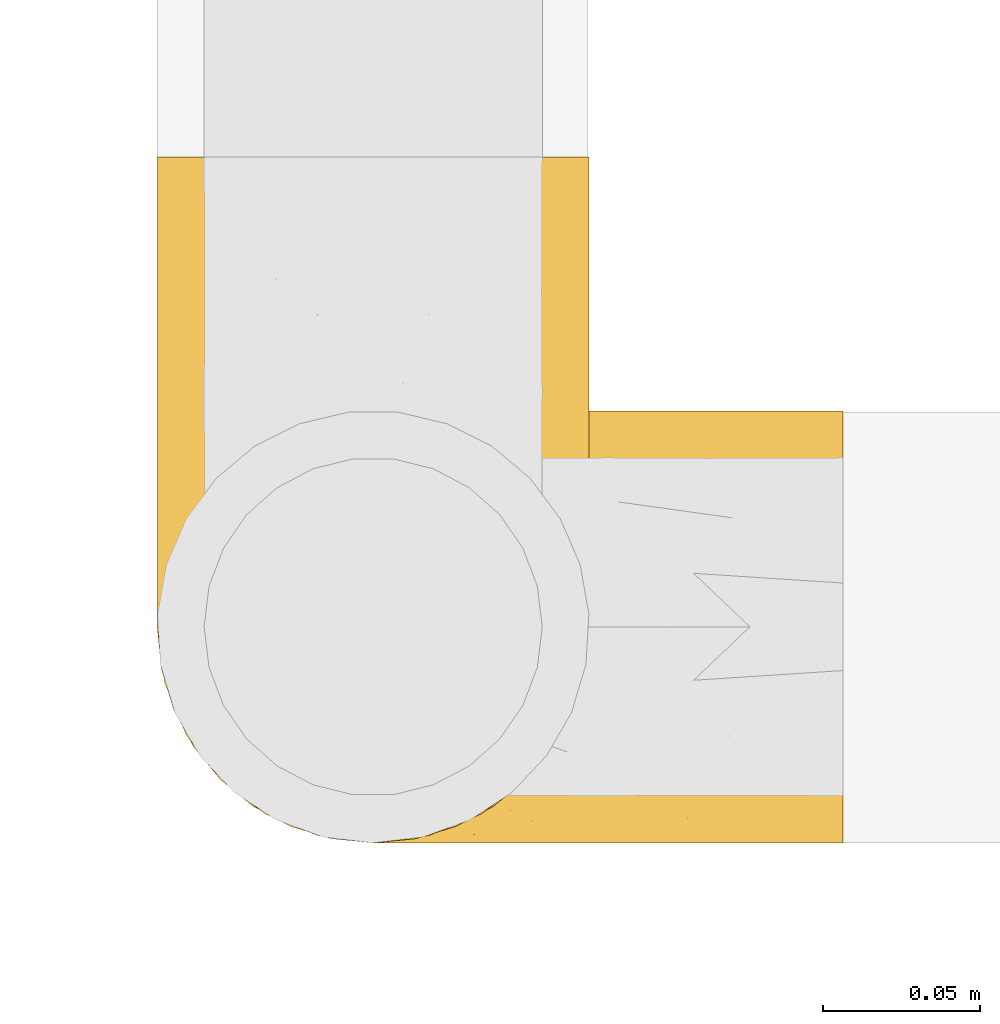
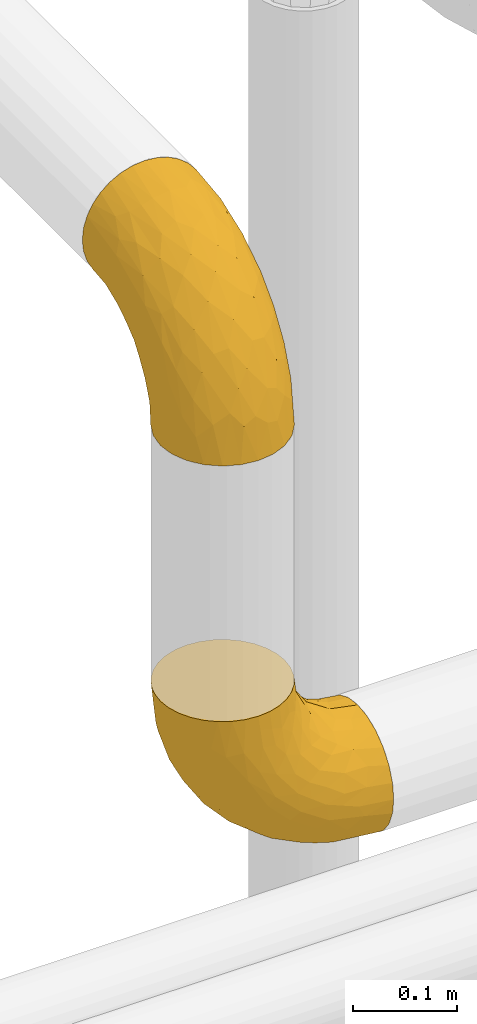
# One storey, part 436 of 827: 2 coverings.
"""IFC2X3 building model written with IfcOpenShell, lengths in millimetres."""

from ifc_helpers import new_model, entity, si_unit, converted_unit, derived_unit, direction, frame, origin, place, context, subcontext, project, spatial, faceted_brep, element, save


model = new_model("IFC2X3")

# Units and contexts
model_context = context("Model", 3, precision=0.01, world=origin(), true_north=direction((6.12303176911189e-17, 1.0)))
body_context = subcontext(model_context, "Body", "Model", "MODEL_VIEW")
ifc_project = project(units=[si_unit("LENGTHUNIT", "METRE", prefix="MILLI"), si_unit("AREAUNIT", "SQUARE_METRE"), si_unit("VOLUMEUNIT", "CUBIC_METRE"), converted_unit("PLANEANGLEUNIT", "DEGREE", entity("IfcRatioMeasure", 0.0174532925199433), si_unit("PLANEANGLEUNIT", "RADIAN"), dimensions=[0, 0, 0, 0, 0, 0, 0]), si_unit("MASSUNIT", "GRAM", prefix="KILO"), derived_unit("MASSDENSITYUNIT", [(si_unit("MASSUNIT", "GRAM", prefix="KILO"), 1), (si_unit("LENGTHUNIT", "METRE"), -3)]), derived_unit("MOMENTOFINERTIAUNIT", [(si_unit("LENGTHUNIT", "METRE"), 4)]), si_unit("TIMEUNIT", "SECOND"), si_unit("FREQUENCYUNIT", "HERTZ"), si_unit("THERMODYNAMICTEMPERATUREUNIT", "DEGREE_CELSIUS"), derived_unit("THERMALTRANSMITTANCEUNIT", [(si_unit("MASSUNIT", "GRAM", prefix="KILO"), 1), (si_unit("THERMODYNAMICTEMPERATUREUNIT", "KELVIN"), -1), (si_unit("TIMEUNIT", "SECOND"), -3)]), derived_unit("VOLUMETRICFLOWRATEUNIT", [(si_unit("LENGTHUNIT", "METRE"), 3), (si_unit("TIMEUNIT", "SECOND"), -1)]), derived_unit("MASSFLOWRATEUNIT", [(si_unit("MASSUNIT", "GRAM", prefix="KILO"), 1), (si_unit("TIMEUNIT", "SECOND"), -1)]), derived_unit("ROTATIONALFREQUENCYUNIT", [(si_unit("TIMEUNIT", "SECOND"), -1)]), si_unit("ELECTRICCURRENTUNIT", "AMPERE"), si_unit("ELECTRICVOLTAGEUNIT", "VOLT"), si_unit("POWERUNIT", "WATT"), si_unit("FORCEUNIT", "NEWTON", prefix="KILO"), si_unit("ILLUMINANCEUNIT", "LUX"), si_unit("LUMINOUSFLUXUNIT", "LUMEN"), si_unit("LUMINOUSINTENSITYUNIT", "CANDELA"), derived_unit("USERDEFINED", [(si_unit("MASSUNIT", "GRAM", prefix="KILO"), -1), (si_unit("LENGTHUNIT", "METRE"), -2), (si_unit("TIMEUNIT", "SECOND"), 3), (si_unit("LUMINOUSFLUXUNIT", "LUMEN"), 1)]), derived_unit("LINEARVELOCITYUNIT", [(si_unit("LENGTHUNIT", "METRE"), 1), (si_unit("TIMEUNIT", "SECOND"), -1)]), si_unit("PRESSUREUNIT", "PASCAL"), derived_unit("USERDEFINED", [(si_unit("LENGTHUNIT", "METRE"), -2), (si_unit("MASSUNIT", "GRAM", prefix="KILO"), 1), (si_unit("TIMEUNIT", "SECOND"), -2)]), derived_unit("LINEARFORCEUNIT", [(si_unit("MASSUNIT", "GRAM", prefix="KILO"), 1), (si_unit("LENGTHUNIT", "METRE"), 1), (si_unit("TIMEUNIT", "SECOND"), -2), (si_unit("LENGTHUNIT", "METRE"), -1)]), derived_unit("PLANARFORCEUNIT", [(si_unit("MASSUNIT", "GRAM", prefix="KILO"), 1), (si_unit("LENGTHUNIT", "METRE"), 1), (si_unit("TIMEUNIT", "SECOND"), -2), (si_unit("LENGTHUNIT", "METRE"), -2)])], contexts=[model_context])

# Site, building, storey
site_placement = place(None, origin())
site = spatial("IfcSite", under=ifc_project, at=site_placement, CompositionType="ELEMENT")
building_placement = place(site_placement, origin())
building = spatial("IfcBuilding", under=site, at=building_placement, CompositionType="ELEMENT")
storey_placement = place(building_placement, frame((0.0, 0.0, 28200.0)))
storey = spatial("IfcBuildingStorey", under=building, at=storey_placement, Name="08", CompositionType="ELEMENT", Elevation=28200.0)

# Coverings
covering_1_placement = place(storey_placement, frame((55540.45, 17859.5, 2829.37)))
element("IfcCovering", 1, at=covering_1_placement, inside=storey, Name=":ADSK_", ObjectType=":ADSK_", PredefinedType="INSULATION", context=body_context, shape_type="Brep", body=[
    faceted_brep([(44.18, 134.34, 220.6), (32.25, 127.96, 220.6), (21.8, 119.38, 220.6), (13.22, 108.92, 220.6), (6.84, 96.99, 220.6), (2.92, 84.05, 220.6), (1.6, 70.6, 220.6), (2.92, 57.13, 220.6), (6.85, 44.18, 220.6), (13.23, 32.25, 220.6), (21.81, 21.8, 220.6), (32.27, 13.22, 220.6), (44.2, 6.84, 220.6), (57.14, 2.92, 220.6), (70.6, 1.6, 220.6), (84.06, 2.92, 220.6), (97.01, 6.85, 220.6), (108.94, 13.23, 220.6), (119.39, 21.81, 220.6), (127.97, 32.27, 220.6), (134.35, 44.2, 220.6), (138.27, 57.14, 220.6), (139.6, 70.6, 220.6), (138.27, 84.06, 220.6), (134.34, 97.01, 220.6), (127.96, 108.94, 220.6), (119.38, 119.39, 220.6), (108.92, 127.97, 220.6), (96.99, 134.35, 220.6), (84.05, 138.27, 220.6), (70.6, 139.6, 220.6), (57.13, 138.27, 220.6), (220.6, 36.1, 130.35), (220.6, 21.8, 119.39), (220.6, 10.84, 105.1), (220.6, 3.95, 88.45), (220.6, 2.92, 80.67), (220.6, 1.6, 70.6), (220.6, 3.95, 52.74), (220.6, 10.84, 36.1), (220.6, 21.8, 21.8), (220.6, 36.1, 10.84), (220.6, 52.74, 3.95), (220.6, 70.6, 1.6), (220.6, 88.45, 3.95), (220.6, 105.1, 10.84), (220.6, 119.39, 21.8), (220.6, 130.35, 36.1), (220.6, 137.24, 52.74), (220.6, 139.6, 70.6), (220.6, 138.27, 80.67), (220.6, 137.24, 88.45), (220.6, 130.35, 105.1), (220.6, 119.39, 119.39), (220.6, 105.1, 130.35), (220.6, 88.45, 137.24), (220.6, 70.6, 139.6), (220.6, 52.74, 137.24), (125.57, 70.6, 23.28), (141.61, 83.48, 17.64), (171.86, 70.6, 7.09), (178.84, 83.77, 6.91), (72.46, 138.42, 153.3), (62.85, 138.7, 187.95), (75.71, 139.6, 181.77), (163.94, 95.16, 13.73), (84.05, 70.6, 49.37), (49.37, 70.6, 84.05), (67.42, 88.55, 67.42), (55.49, 134.98, 163.19), (41.48, 129.07, 168.15), (172.96, 131.06, 43.66), (152.88, 122.45, 37.17), (128.71, 129.1, 58.2), (105.17, 83.61, 35.94), (82.66, 127.05, 90.42), (110.03, 122.02, 58.75), (73.41, 117.32, 84.04), (58.01, 127.76, 124.91), (175.72, 110.77, 19.44), (89.2, 108.41, 59.72), (125.48, 111.97, 38.75), (191.27, 124.14, 29.31), (118.05, 137.81, 90.59), (114.53, 139.6, 114.53), (130.06, 139.6, 102.61), (145.6, 139.6, 90.69), (25.58, 99.97, 136.35), (41.09, 111.29, 120.09), (49.61, 100.2, 94.71), (180.8, 136.96, 56.47), (36.76, 120.82, 148.93), (143.84, 134.72, 62.8), (153.77, 138.53, 72.92), (163.68, 139.6, 83.2), (181.77, 139.6, 75.71), (36.22, 85.56, 105.48), (18.72, 83.03, 138.66), (108.58, 98.49, 39.3), (28.1, 122.52, 186.81), (20.51, 112.56, 177.02), (9.7, 89.27, 172.0), (7.09, 70.6, 171.86), (14.38, 101.45, 172.65), (72.84, 139.6, 203.54), (82.11, 133.88, 109.58), (93.43, 138.52, 120.02), (83.2, 139.6, 163.68), (90.69, 139.6, 145.6), (108.41, 132.65, 79.61), (23.28, 70.6, 125.57), (102.61, 139.6, 130.06), (192.66, 139.6, 74.27), (203.54, 139.6, 72.84), (142.03, 94.19, 187.75), (132.35, 106.02, 199.25), (192.52, 136.83, 93.0), (99.95, 134.87, 188.21), (116.93, 130.69, 168.34), (96.46, 138.16, 165.08), (150.71, 133.28, 121.62), (163.75, 126.08, 127.61), (170.88, 131.6, 113.84), (124.66, 118.74, 190.42), (135.88, 111.83, 178.31), (133.73, 123.27, 160.84), (155.7, 137.55, 104.12), (176.56, 135.67, 101.41), (112.66, 127.06, 197.73), (123.77, 133.33, 147.57), (133.08, 137.19, 121.84), (112.09, 137.97, 140.06), (197.78, 128.39, 110.63), (182.01, 101.84, 140.98), (196.55, 86.49, 141.3), (203.22, 99.1, 135.18), (148.02, 100.79, 170.91), (174.12, 86.27, 152.06), (147.99, 111.58, 160.12), (189.6, 70.6, 145.76), (163.32, 70.6, 163.32), (190.99, 116.89, 126.29), (155.31, 86.82, 169.45), (145.76, 70.6, 189.6), (86.59, 138.09, 199.29), (165.06, 116.82, 138.92), (161.33, 99.48, 156.44), (140.96, 129.97, 137.84), (147.95, 121.73, 146.63), (180.78, 125.02, 120.65), (154.28, 47.08, 167.21), (168.9, 49.2, 153.88), (114.34, 11.95, 180.27), (99.94, 6.82, 193.45), (102.81, 4.25, 163.13), (186.04, 53.51, 144.97), (174.36, 38.34, 144.54), (198.65, 41.46, 135.94), (197.78, 12.8, 110.63), (188.15, 23.89, 126.84), (170.88, 9.59, 113.84), (121.11, 8.56, 153.87), (130.33, 21.21, 173.48), (155.03, 27.96, 150.81), (160.46, 17.86, 133.91), (172.66, 27.1, 136.92), (139.19, 48.02, 196.84), (136.42, 32.97, 183.06), (202.91, 53.08, 139.23), (142.29, 27.99, 165.54), (123.93, 23.19, 195.54), (131.85, 35.67, 202.93), (86.6, 3.1, 199.28), (192.52, 4.37, 93.0), (212.07, 1.6, 71.72), (181.77, 1.6, 75.71), (203.54, 1.6, 72.84), (167.07, 2.93, 95.03), (163.68, 1.6, 83.2), (149.05, 3.68, 108.27), (138.43, 17.11, 152.99), (141.57, 7.87, 128.64), (112.64, 14.69, 201.9), (90.66, 2.91, 178.55), (75.71, 1.6, 181.77), (72.84, 1.6, 203.54), (112.26, 2.92, 137.45), (90.69, 1.6, 145.6), (102.61, 1.6, 130.06), (114.53, 1.6, 114.53), (83.2, 1.6, 163.68), (128.17, 3.18, 121.81), (130.06, 1.6, 102.61), (145.6, 1.6, 90.69), (118.5, 3.26, 90.88), (90.48, 3.41, 117.93), (84.57, 7.26, 106.76), (51.96, 12.98, 137.57), (40.41, 11.38, 176.86), (36.78, 20.36, 148.92), (41.14, 29.89, 120.02), (20.52, 28.62, 177.02), (25.6, 41.21, 136.31), (189.22, 2.7, 61.37), (56.17, 4.33, 180.57), (49.62, 41.0, 94.7), (72.69, 2.7, 153.71), (150.58, 52.64, 15.6), (183.31, 57.93, 5.98), (187.16, 45.26, 9.04), (36.22, 55.63, 105.48), (169.53, 30.68, 20.73), (173.26, 8.42, 47.01), (28.12, 18.66, 186.8), (105.17, 57.58, 35.94), (108.58, 42.7, 39.3), (150.31, 3.64, 69.45), (156.03, 41.02, 18.31), (67.42, 52.64, 67.42), (77.56, 39.64, 64.57), (53.96, 20.5, 114.68), (62.51, 6.62, 143.56), (185.29, 17.3, 30.01), (142.92, 19.21, 40.58), (139.61, 7.94, 61.08), (105.58, 17.12, 64.86), (109.18, 7.56, 81.7), (20.53, 52.86, 137.37), (11.92, 39.53, 185.44), (9.71, 51.91, 171.98), (73.45, 23.86, 84.01), (106.78, 28.24, 50.73), (77.17, 13.13, 98.75), (133.64, 33.14, 31.7)], [[[0, 1, 2, 3, 4, 5, 6, 7, 8, 9, 10, 11, 12, 13, 14, 15, 16, 17, 18, 19, 20, 21, 22, 23, 24, 25, 26, 27, 28, 29, 30, 31]], [[32, 33, 34, 35, 36, 37, 38, 39, 40, 41, 42, 43, 44, 45, 46, 47, 48, 49, 50, 51, 52, 53, 54, 55, 56, 57]], [[58, 59, 60]], [[61, 43, 60]], [[62, 63, 64]], [[44, 65, 45]], [[66, 67, 68]], [[69, 70, 0]], [[71, 72, 73]], [[58, 74, 59]], [[75, 76, 77]], [[74, 58, 66]], [[77, 78, 75]], [[79, 46, 45]], [[80, 76, 81]], [[79, 45, 65]], [[47, 46, 82]], [[83, 84, 85, 86]], [[87, 88, 89]], [[49, 48, 90]], [[91, 70, 78]], [[90, 92, 93]], [[93, 86, 94, 95]], [[87, 96, 97]], [[74, 68, 98]], [[78, 70, 69]], [[70, 91, 99]], [[2, 99, 100]], [[4, 101, 5]], [[102, 101, 97]], [[81, 79, 65]], [[3, 100, 103]], [[68, 96, 89]], [[4, 3, 103]], [[59, 61, 60]], [[102, 6, 5]], [[86, 93, 83]], [[99, 2, 1]], [[68, 89, 80]], [[63, 69, 31]], [[63, 30, 104, 64]], [[92, 90, 71]], [[101, 103, 87]], [[69, 0, 31]], [[105, 62, 106]], [[62, 64, 107, 108]], [[88, 100, 91]], [[83, 106, 84]], [[3, 2, 100]], [[109, 83, 92]], [[96, 67, 110]], [[96, 68, 67]], [[106, 108, 111, 84]], [[102, 5, 101]], [[105, 69, 62]], [[90, 95, 112, 113, 49]], [[83, 93, 92]], [[97, 96, 110]], [[89, 96, 87]], [[95, 90, 93]], [[71, 48, 47]], [[48, 71, 90]], [[82, 71, 47]], [[81, 65, 98]], [[82, 79, 72]], [[1, 0, 70]], [[100, 99, 91]], [[70, 99, 1]], [[78, 69, 105]], [[75, 78, 105]], [[88, 78, 77]], [[87, 100, 88]], [[77, 76, 80]], [[78, 88, 91]], [[77, 89, 88]], [[68, 74, 66]], [[59, 98, 65]], [[105, 109, 75]], [[73, 76, 75]], [[75, 109, 73]], [[81, 76, 72]], [[79, 81, 72]], [[81, 98, 80]], [[83, 109, 105]], [[109, 92, 73]], [[68, 80, 98]], [[89, 77, 80]], [[98, 59, 74]], [[59, 65, 61]], [[65, 44, 61]], [[43, 61, 44]], [[71, 73, 92]], [[72, 76, 73]], [[69, 63, 62]], [[30, 63, 31]], [[105, 106, 83]], [[108, 106, 62]], [[79, 82, 46]], [[71, 82, 72]], [[4, 103, 101]], [[100, 87, 103]], [[102, 97, 110]], [[87, 97, 101]], [[24, 114, 115]], [[116, 112, 95]], [[116, 51, 112]], [[117, 118, 119]], [[52, 51, 116]], [[120, 121, 122]], [[123, 124, 125]], [[94, 126, 127]], [[117, 27, 128]], [[129, 130, 131]], [[124, 123, 115]], [[53, 52, 132]], [[133, 134, 135]], [[84, 131, 130]], [[114, 136, 124]], [[56, 55, 134]], [[134, 133, 137]], [[124, 136, 138]], [[139, 137, 140]], [[54, 53, 141]], [[123, 25, 115]], [[94, 86, 126]], [[26, 128, 27]], [[142, 143, 140]], [[117, 28, 27]], [[123, 26, 25]], [[132, 141, 53]], [[28, 144, 29]], [[144, 104, 29]], [[25, 24, 115]], [[133, 141, 145]], [[118, 128, 123]], [[143, 23, 22]], [[143, 114, 23]], [[141, 133, 135]], [[136, 142, 146]], [[119, 144, 117]], [[137, 142, 140]], [[23, 114, 24]], [[119, 131, 108]], [[118, 117, 128]], [[126, 85, 130]], [[28, 117, 144]], [[128, 26, 123]], [[107, 144, 119]], [[116, 127, 132]], [[107, 119, 108]], [[64, 144, 107]], [[131, 84, 111, 108]], [[119, 118, 131]], [[131, 118, 129]], [[125, 118, 123]], [[138, 146, 145]], [[147, 120, 130]], [[120, 126, 130]], [[114, 124, 115]], [[124, 138, 125]], [[148, 138, 145]], [[129, 125, 147]], [[116, 132, 52]], [[132, 122, 149]], [[121, 149, 122]], [[125, 148, 147]], [[134, 137, 139]], [[133, 145, 146]], [[146, 142, 137]], [[143, 142, 114]], [[133, 146, 137]], [[136, 146, 138]], [[56, 134, 139]], [[134, 55, 135]], [[55, 54, 135]], [[141, 135, 54]], [[104, 144, 64]], [[104, 30, 29]], [[142, 136, 114]], [[50, 49, 113, 112, 51]], [[116, 95, 94]], [[125, 129, 118]], [[130, 129, 147]], [[147, 148, 121]], [[126, 120, 122]], [[127, 126, 122]], [[138, 148, 125]], [[147, 121, 120]], [[149, 145, 141]], [[145, 149, 121]], [[132, 149, 141]], [[132, 127, 122]], [[94, 127, 116]], [[85, 126, 86]], [[85, 84, 130]], [[121, 148, 145]], [[140, 150, 151]], [[152, 153, 154]], [[155, 156, 157]], [[158, 159, 160]], [[152, 161, 162]], [[163, 164, 165]], [[166, 167, 150]], [[155, 168, 139]], [[167, 162, 169]], [[170, 167, 171]], [[15, 172, 16]], [[155, 151, 156]], [[34, 173, 35]], [[174, 37, 36, 35, 175, 176]], [[143, 21, 166]], [[34, 33, 158]], [[143, 150, 140]], [[173, 177, 178]], [[33, 32, 159]], [[166, 150, 143]], [[160, 179, 177]], [[143, 22, 21]], [[161, 180, 162]], [[179, 160, 181]], [[171, 166, 20]], [[32, 57, 157]], [[20, 166, 21]], [[17, 182, 18]], [[18, 170, 19]], [[153, 17, 16]], [[161, 152, 154]], [[183, 172, 184]], [[170, 162, 167]], [[153, 152, 182]], [[181, 164, 180]], [[180, 161, 181]], [[182, 170, 18]], [[184, 172, 185]], [[172, 15, 185]], [[157, 159, 32]], [[164, 163, 180]], [[186, 187, 188, 189]], [[20, 19, 171]], [[158, 173, 34]], [[183, 153, 172]], [[170, 171, 19]], [[166, 171, 167]], [[190, 187, 183, 184]], [[153, 16, 172]], [[183, 187, 154]], [[139, 168, 56]], [[157, 156, 165]], [[153, 182, 17]], [[170, 182, 152]], [[168, 155, 157]], [[140, 155, 139]], [[154, 186, 161]], [[160, 159, 164]], [[191, 161, 186]], [[191, 192, 179]], [[187, 186, 154]], [[191, 186, 189]], [[159, 158, 33]], [[173, 158, 160]], [[160, 164, 181]], [[165, 164, 159]], [[156, 150, 163]], [[169, 150, 167]], [[15, 14, 185]], [[152, 162, 170]], [[169, 180, 163]], [[180, 169, 162]], [[150, 169, 163]], [[154, 153, 183]], [[179, 181, 191]], [[177, 179, 193]], [[178, 175, 173]], [[160, 177, 173]], [[177, 193, 178]], [[161, 191, 181]], [[140, 151, 155]], [[150, 156, 151]], [[175, 35, 173]], [[157, 57, 168]], [[56, 168, 57]], [[157, 165, 159]], [[163, 165, 156]], [[192, 191, 189]], [[192, 193, 179]], [[194, 195, 196]], [[197, 198, 199]], [[200, 201, 202]], [[203, 37, 174, 176, 175]], [[198, 204, 12]], [[200, 202, 205]], [[206, 187, 190, 184]], [[189, 195, 194]], [[58, 60, 207]], [[10, 9, 201]], [[43, 42, 208]], [[209, 207, 208]], [[67, 210, 110]], [[211, 41, 40]], [[205, 202, 210]], [[203, 212, 38]], [[213, 198, 11]], [[214, 207, 215]], [[216, 175, 178, 193]], [[207, 209, 217]], [[218, 219, 205]], [[200, 220, 199]], [[195, 206, 221]], [[198, 221, 204]], [[210, 67, 218]], [[222, 40, 39]], [[14, 13, 204]], [[221, 206, 204]], [[198, 12, 11]], [[221, 197, 196]], [[66, 214, 218]], [[223, 224, 225]], [[203, 175, 216]], [[195, 189, 188, 187]], [[194, 226, 216]], [[213, 201, 199]], [[58, 214, 66]], [[67, 66, 218]], [[110, 210, 227]], [[213, 11, 10]], [[202, 201, 228]], [[7, 102, 229]], [[6, 102, 7]], [[230, 231, 225]], [[231, 219, 215]], [[7, 229, 8]], [[228, 8, 229]], [[38, 212, 39]], [[227, 102, 110]], [[225, 232, 230]], [[9, 8, 228]], [[40, 222, 211]], [[41, 209, 42]], [[223, 231, 233]], [[211, 217, 209]], [[205, 210, 218]], [[229, 227, 202]], [[226, 224, 216]], [[222, 212, 223]], [[201, 213, 10]], [[198, 213, 199]], [[219, 218, 215]], [[200, 199, 201]], [[205, 230, 200]], [[220, 200, 230]], [[207, 214, 58]], [[218, 214, 215]], [[233, 215, 217]], [[230, 205, 219]], [[225, 231, 223]], [[230, 219, 231]], [[224, 223, 212]], [[232, 225, 226]], [[196, 232, 226]], [[220, 197, 199]], [[230, 232, 220]], [[232, 196, 197]], [[232, 197, 220]], [[198, 197, 221]], [[212, 222, 39]], [[211, 222, 223]], [[187, 206, 195]], [[204, 184, 185, 14]], [[184, 204, 206]], [[204, 13, 12]], [[211, 209, 41]], [[208, 207, 60]], [[43, 208, 60]], [[42, 209, 208]], [[233, 217, 211]], [[215, 207, 217]], [[223, 233, 211]], [[215, 233, 231]], [[212, 203, 216]], [[37, 203, 38]], [[216, 193, 194]], [[194, 193, 192, 189]], [[202, 228, 229]], [[9, 228, 201]], [[227, 229, 102]], [[210, 202, 227]], [[225, 224, 226]], [[212, 216, 224]], [[194, 196, 226]], [[221, 196, 195]]]),
])
covering_2_placement = place(storey_placement, frame((55540.45, 17859.5, 3348.15)))
element("IfcCovering", 2, at=covering_2_placement, inside=storey, Name=":ADSK_", ObjectType=":ADSK_", PredefinedType="INSULATION", context=body_context, shape_type="Brep", body=[
    faceted_brep([(6.85, 220.6, 178.01), (13.23, 220.6, 189.94), (21.81, 220.6, 200.39), (32.27, 220.6, 208.97), (44.2, 220.6, 215.35), (57.14, 220.6, 219.27), (70.6, 220.6, 220.6), (84.06, 220.6, 219.27), (97.01, 220.6, 215.34), (108.94, 220.6, 208.96), (119.39, 220.6, 200.38), (127.97, 220.6, 189.92), (134.35, 220.6, 177.99), (138.27, 220.6, 165.05), (139.6, 220.6, 151.6), (138.27, 220.6, 138.13), (134.34, 220.6, 125.18), (127.96, 220.6, 113.25), (119.38, 220.6, 102.8), (108.92, 220.6, 94.22), (96.99, 220.6, 87.84), (84.05, 220.6, 83.92), (70.6, 220.6, 82.6), (57.13, 220.6, 83.92), (44.18, 220.6, 87.85), (32.25, 220.6, 94.23), (21.8, 220.6, 102.81), (13.22, 220.6, 113.27), (6.84, 220.6, 125.2), (2.92, 220.6, 138.14), (1.6, 220.6, 151.6), (2.92, 220.6, 165.06), (105.1, 130.35, 1.6), (119.39, 119.39, 1.6), (130.35, 105.1, 1.6), (137.24, 88.45, 1.6), (138.27, 80.67, 1.6), (139.6, 70.6, 1.6), (137.24, 52.74, 1.6), (130.35, 36.1, 1.6), (119.39, 21.8, 1.6), (105.1, 10.84, 1.6), (88.45, 3.95, 1.6), (70.6, 1.6, 1.6), (52.74, 3.95, 1.6), (36.1, 10.84, 1.6), (21.8, 21.8, 1.6), (10.84, 36.1, 1.6), (3.95, 52.74, 1.6), (1.6, 70.6, 1.6), (2.92, 80.67, 1.6), (3.95, 88.45, 1.6), (10.84, 105.1, 1.6), (21.8, 119.39, 1.6), (36.1, 130.35, 1.6), (52.74, 137.24, 1.6), (70.6, 139.6, 1.6), (88.45, 137.24, 1.6), (70.6, 23.28, 96.62), (57.71, 17.64, 80.58), (70.6, 7.09, 50.33), (57.42, 6.91, 43.35), (2.77, 153.3, 149.73), (2.49, 187.95, 159.34), (1.6, 181.77, 146.48), (46.03, 13.73, 58.25), (70.6, 49.37, 138.14), (70.6, 84.05, 172.82), (52.64, 67.42, 154.77), (6.21, 163.19, 166.7), (12.12, 168.15, 180.71), (10.13, 43.66, 49.23), (18.74, 37.17, 69.31), (12.09, 58.2, 93.48), (57.58, 35.94, 117.02), (14.14, 90.42, 139.53), (19.17, 58.75, 112.16), (23.87, 84.04, 148.78), (13.43, 124.91, 164.18), (30.42, 19.44, 46.47), (32.79, 59.72, 132.99), (29.22, 38.75, 96.71), (17.05, 29.31, 30.92), (3.38, 90.59, 104.14), (1.6, 114.53, 107.66), (1.6, 102.61, 92.13), (1.6, 90.69, 76.6), (41.22, 136.35, 196.61), (29.9, 120.09, 181.1), (40.99, 94.71, 172.58), (4.23, 56.47, 41.4), (20.37, 148.93, 185.43), (6.47, 62.8, 78.35), (2.66, 72.92, 68.43), (1.6, 83.2, 58.51), (1.6, 75.71, 40.42), (55.63, 105.48, 185.97), (58.16, 138.66, 203.47), (42.7, 39.3, 113.61), (18.67, 186.81, 194.09), (28.63, 177.02, 201.68), (51.92, 172.0, 212.49), (70.6, 171.86, 215.1), (39.74, 172.65, 207.81), (1.6, 203.54, 149.35), (7.31, 109.58, 140.08), (2.67, 120.02, 128.76), (1.6, 163.68, 138.99), (1.6, 145.6, 131.5), (8.54, 79.61, 113.78), (70.6, 125.57, 198.91), (1.6, 130.06, 119.58), (1.6, 74.27, 29.53), (1.6, 72.84, 18.65), (47.0, 187.75, 80.16), (35.17, 199.25, 89.84), (4.37, 93.0, 29.67), (6.32, 188.21, 122.24), (10.5, 168.34, 105.26), (3.03, 165.08, 125.73), (7.91, 121.62, 71.48), (15.11, 127.61, 58.44), (9.59, 113.84, 51.31), (22.45, 190.42, 97.53), (29.36, 178.31, 86.31), (17.92, 160.84, 88.46), (3.64, 104.12, 66.49), (5.52, 101.41, 45.64), (14.14, 197.73, 109.54), (7.86, 147.57, 98.42), (4.0, 121.84, 89.11), (3.22, 140.06, 110.1), (12.8, 110.63, 24.41), (39.36, 140.98, 40.18), (54.7, 141.3, 25.64), (42.09, 135.18, 18.97), (40.4, 170.91, 74.17), (54.92, 152.06, 48.07), (29.61, 160.12, 74.2), (70.6, 145.76, 32.59), (70.6, 163.32, 58.87), (24.3, 126.29, 31.2), (54.37, 169.45, 66.88), (70.6, 189.6, 76.43), (3.1, 199.29, 135.6), (24.37, 138.92, 57.13), (41.71, 156.44, 60.86), (11.22, 137.84, 81.23), (19.46, 146.63, 74.24), (16.17, 120.65, 41.41), (94.11, 167.21, 67.91), (91.99, 153.88, 53.29), (129.24, 180.27, 107.85), (134.37, 193.45, 122.25), (136.94, 163.13, 119.38), (87.68, 144.97, 36.15), (102.85, 144.54, 47.83), (99.73, 135.94, 23.54), (128.39, 110.63, 24.41), (117.3, 126.84, 34.04), (131.6, 113.84, 51.31), (132.63, 153.87, 101.08), (119.98, 173.48, 91.86), (113.23, 150.81, 67.16), (123.33, 133.91, 61.73), (114.09, 136.92, 49.53), (93.17, 196.84, 83.0), (108.22, 183.06, 85.77), (88.12, 139.23, 19.29), (113.21, 165.54, 79.91), (118.0, 195.54, 98.26), (105.52, 202.93, 90.34), (138.09, 199.28, 135.59), (136.83, 93.0, 29.67), (139.6, 71.72, 10.12), (139.6, 75.71, 40.42), (139.6, 72.84, 18.65), (138.26, 95.03, 55.12), (139.6, 83.2, 58.51), (137.51, 108.27, 73.14), (124.08, 152.99, 83.76), (133.32, 128.64, 80.62), (126.5, 201.9, 109.55), (138.28, 178.55, 131.53), (139.6, 181.77, 146.48), (139.6, 203.54, 149.35), (138.27, 137.45, 109.93), (139.6, 145.6, 131.5), (139.6, 130.06, 119.58), (139.6, 114.53, 107.66), (139.6, 163.68, 138.99), (138.01, 121.81, 94.02), (139.6, 102.61, 92.13), (139.6, 90.69, 76.6), (137.93, 90.88, 103.69), (137.78, 117.93, 131.71), (133.93, 106.76, 137.62), (128.21, 137.57, 170.23), (129.81, 176.86, 181.78), (120.83, 148.92, 185.41), (111.3, 120.02, 181.05), (112.57, 177.02, 201.67), (99.98, 136.31, 196.59), (138.49, 61.37, 32.97), (136.86, 180.57, 166.02), (100.19, 94.7, 172.58), (138.49, 153.71, 149.5), (88.55, 15.6, 71.61), (83.26, 5.98, 38.88), (95.93, 9.04, 35.03), (85.56, 105.48, 185.97), (110.51, 20.73, 52.66), (132.77, 47.01, 48.93), (122.53, 186.8, 194.07), (83.61, 35.94, 117.02), (98.49, 39.3, 113.61), (137.55, 69.45, 71.88), (100.17, 18.31, 66.16), (88.55, 67.42, 154.77), (101.55, 64.57, 144.64), (120.69, 114.68, 168.23), (134.57, 143.56, 159.68), (123.89, 30.01, 36.9), (121.98, 40.58, 79.27), (133.25, 61.08, 82.58), (124.07, 64.86, 116.61), (133.63, 81.7, 113.01), (88.33, 137.37, 201.66), (101.66, 185.44, 210.27), (89.29, 171.98, 212.48), (117.33, 84.01, 148.74), (112.95, 50.73, 115.41), (128.06, 98.75, 145.02), (108.06, 31.7, 88.56)], [[[0, 1, 2, 3, 4, 5, 6, 7, 8, 9, 10, 11, 12, 13, 14, 15, 16, 17, 18, 19, 20, 21, 22, 23, 24, 25, 26, 27, 28, 29, 30, 31]], [[32, 33, 34, 35, 36, 37, 38, 39, 40, 41, 42, 43, 44, 45, 46, 47, 48, 49, 50, 51, 52, 53, 54, 55, 56, 57]], [[58, 59, 60]], [[61, 43, 60]], [[62, 63, 64]], [[44, 65, 45]], [[66, 67, 68]], [[69, 70, 0]], [[71, 72, 73]], [[58, 74, 59]], [[75, 76, 77]], [[74, 58, 66]], [[77, 78, 75]], [[79, 46, 45]], [[80, 76, 81]], [[79, 45, 65]], [[47, 46, 82]], [[83, 84, 85, 86]], [[87, 88, 89]], [[49, 48, 90]], [[91, 70, 78]], [[90, 92, 93]], [[93, 86, 94, 95]], [[87, 96, 97]], [[74, 68, 98]], [[78, 70, 69]], [[70, 91, 99]], [[2, 99, 100]], [[4, 101, 5]], [[102, 101, 97]], [[81, 79, 65]], [[3, 100, 103]], [[68, 96, 89]], [[4, 3, 103]], [[59, 61, 60]], [[102, 6, 5]], [[86, 93, 83]], [[99, 2, 1]], [[68, 89, 80]], [[63, 69, 31]], [[63, 30, 104, 64]], [[92, 90, 71]], [[101, 103, 87]], [[69, 0, 31]], [[105, 62, 106]], [[62, 64, 107, 108]], [[88, 100, 91]], [[83, 106, 84]], [[3, 2, 100]], [[109, 83, 92]], [[96, 67, 110]], [[96, 68, 67]], [[106, 108, 111, 84]], [[102, 5, 101]], [[105, 69, 62]], [[90, 95, 112, 113, 49]], [[83, 93, 92]], [[97, 96, 110]], [[89, 96, 87]], [[95, 90, 93]], [[71, 48, 47]], [[48, 71, 90]], [[82, 71, 47]], [[81, 65, 98]], [[82, 79, 72]], [[1, 0, 70]], [[100, 99, 91]], [[70, 99, 1]], [[78, 69, 105]], [[75, 78, 105]], [[88, 78, 77]], [[87, 100, 88]], [[77, 76, 80]], [[78, 88, 91]], [[77, 89, 88]], [[68, 74, 66]], [[59, 98, 65]], [[105, 109, 75]], [[73, 76, 75]], [[75, 109, 73]], [[81, 76, 72]], [[79, 81, 72]], [[81, 98, 80]], [[83, 109, 105]], [[109, 92, 73]], [[68, 80, 98]], [[89, 77, 80]], [[98, 59, 74]], [[59, 65, 61]], [[65, 44, 61]], [[43, 61, 44]], [[71, 73, 92]], [[72, 76, 73]], [[69, 63, 62]], [[30, 63, 31]], [[105, 106, 83]], [[108, 106, 62]], [[79, 82, 46]], [[71, 82, 72]], [[4, 103, 101]], [[100, 87, 103]], [[102, 97, 110]], [[87, 97, 101]], [[24, 114, 115]], [[116, 112, 95]], [[116, 51, 112]], [[117, 118, 119]], [[52, 51, 116]], [[120, 121, 122]], [[123, 124, 125]], [[94, 126, 127]], [[117, 27, 128]], [[129, 130, 131]], [[124, 123, 115]], [[53, 52, 132]], [[133, 134, 135]], [[84, 131, 130]], [[114, 136, 124]], [[56, 55, 134]], [[134, 133, 137]], [[124, 136, 138]], [[139, 137, 140]], [[54, 53, 141]], [[123, 25, 115]], [[94, 86, 126]], [[26, 128, 27]], [[142, 143, 140]], [[117, 28, 27]], [[123, 26, 25]], [[132, 141, 53]], [[28, 144, 29]], [[144, 104, 29]], [[25, 24, 115]], [[133, 141, 145]], [[118, 128, 123]], [[143, 23, 22]], [[143, 114, 23]], [[141, 133, 135]], [[136, 142, 146]], [[119, 144, 117]], [[137, 142, 140]], [[23, 114, 24]], [[119, 131, 108]], [[118, 117, 128]], [[126, 85, 130]], [[28, 117, 144]], [[128, 26, 123]], [[107, 144, 119]], [[116, 127, 132]], [[107, 119, 108]], [[64, 144, 107]], [[131, 84, 111, 108]], [[119, 118, 131]], [[131, 118, 129]], [[125, 118, 123]], [[138, 146, 145]], [[147, 120, 130]], [[120, 126, 130]], [[114, 124, 115]], [[124, 138, 125]], [[148, 138, 145]], [[129, 125, 147]], [[116, 132, 52]], [[132, 122, 149]], [[121, 149, 122]], [[125, 148, 147]], [[134, 137, 139]], [[133, 145, 146]], [[146, 142, 137]], [[143, 142, 114]], [[133, 146, 137]], [[136, 146, 138]], [[56, 134, 139]], [[134, 55, 135]], [[55, 54, 135]], [[141, 135, 54]], [[104, 144, 64]], [[104, 30, 29]], [[142, 136, 114]], [[50, 49, 113, 112, 51]], [[116, 95, 94]], [[125, 129, 118]], [[130, 129, 147]], [[147, 148, 121]], [[126, 120, 122]], [[127, 126, 122]], [[138, 148, 125]], [[147, 121, 120]], [[149, 145, 141]], [[145, 149, 121]], [[132, 149, 141]], [[132, 127, 122]], [[94, 127, 116]], [[85, 126, 86]], [[85, 84, 130]], [[121, 148, 145]], [[140, 150, 151]], [[152, 153, 154]], [[155, 156, 157]], [[158, 159, 160]], [[152, 161, 162]], [[163, 164, 165]], [[166, 167, 150]], [[155, 168, 139]], [[167, 162, 169]], [[170, 167, 171]], [[15, 172, 16]], [[155, 151, 156]], [[34, 173, 35]], [[174, 37, 36, 35, 175, 176]], [[143, 21, 166]], [[34, 33, 158]], [[143, 150, 140]], [[173, 177, 178]], [[33, 32, 159]], [[166, 150, 143]], [[160, 179, 177]], [[143, 22, 21]], [[161, 180, 162]], [[179, 160, 181]], [[171, 166, 20]], [[32, 57, 157]], [[20, 166, 21]], [[17, 182, 18]], [[18, 170, 19]], [[153, 17, 16]], [[161, 152, 154]], [[183, 172, 184]], [[170, 162, 167]], [[153, 152, 182]], [[181, 164, 180]], [[180, 161, 181]], [[182, 170, 18]], [[184, 172, 185]], [[172, 15, 185]], [[157, 159, 32]], [[164, 163, 180]], [[186, 187, 188, 189]], [[20, 19, 171]], [[158, 173, 34]], [[183, 153, 172]], [[170, 171, 19]], [[166, 171, 167]], [[190, 187, 183, 184]], [[153, 16, 172]], [[183, 187, 154]], [[139, 168, 56]], [[157, 156, 165]], [[153, 182, 17]], [[170, 182, 152]], [[168, 155, 157]], [[140, 155, 139]], [[154, 186, 161]], [[160, 159, 164]], [[191, 161, 186]], [[191, 192, 179]], [[187, 186, 154]], [[191, 186, 189]], [[159, 158, 33]], [[173, 158, 160]], [[160, 164, 181]], [[165, 164, 159]], [[156, 150, 163]], [[169, 150, 167]], [[15, 14, 185]], [[152, 162, 170]], [[169, 180, 163]], [[180, 169, 162]], [[150, 169, 163]], [[154, 153, 183]], [[179, 181, 191]], [[177, 179, 193]], [[178, 175, 173]], [[160, 177, 173]], [[177, 193, 178]], [[161, 191, 181]], [[140, 151, 155]], [[150, 156, 151]], [[175, 35, 173]], [[157, 57, 168]], [[56, 168, 57]], [[157, 165, 159]], [[163, 165, 156]], [[192, 191, 189]], [[192, 193, 179]], [[194, 195, 196]], [[197, 198, 199]], [[200, 201, 202]], [[203, 37, 174, 176, 175]], [[198, 204, 12]], [[200, 202, 205]], [[206, 187, 190, 184]], [[189, 195, 194]], [[58, 60, 207]], [[10, 9, 201]], [[43, 42, 208]], [[209, 207, 208]], [[67, 210, 110]], [[211, 41, 40]], [[205, 202, 210]], [[203, 212, 38]], [[213, 198, 11]], [[214, 207, 215]], [[216, 175, 178, 193]], [[207, 209, 217]], [[218, 219, 205]], [[200, 220, 199]], [[195, 206, 221]], [[198, 221, 204]], [[210, 67, 218]], [[222, 40, 39]], [[14, 13, 204]], [[221, 206, 204]], [[198, 12, 11]], [[221, 197, 196]], [[66, 214, 218]], [[223, 224, 225]], [[203, 175, 216]], [[195, 189, 188, 187]], [[194, 226, 216]], [[213, 201, 199]], [[58, 214, 66]], [[67, 66, 218]], [[110, 210, 227]], [[213, 11, 10]], [[202, 201, 228]], [[7, 102, 229]], [[6, 102, 7]], [[230, 231, 225]], [[231, 219, 215]], [[7, 229, 8]], [[228, 8, 229]], [[38, 212, 39]], [[227, 102, 110]], [[225, 232, 230]], [[9, 8, 228]], [[40, 222, 211]], [[41, 209, 42]], [[223, 231, 233]], [[211, 217, 209]], [[205, 210, 218]], [[229, 227, 202]], [[226, 224, 216]], [[222, 212, 223]], [[201, 213, 10]], [[198, 213, 199]], [[219, 218, 215]], [[200, 199, 201]], [[205, 230, 200]], [[220, 200, 230]], [[207, 214, 58]], [[218, 214, 215]], [[233, 215, 217]], [[230, 205, 219]], [[225, 231, 223]], [[230, 219, 231]], [[224, 223, 212]], [[232, 225, 226]], [[196, 232, 226]], [[220, 197, 199]], [[230, 232, 220]], [[232, 196, 197]], [[232, 197, 220]], [[198, 197, 221]], [[212, 222, 39]], [[211, 222, 223]], [[187, 206, 195]], [[204, 184, 185, 14]], [[184, 204, 206]], [[204, 13, 12]], [[211, 209, 41]], [[208, 207, 60]], [[43, 208, 60]], [[42, 209, 208]], [[233, 217, 211]], [[215, 207, 217]], [[223, 233, 211]], [[215, 233, 231]], [[212, 203, 216]], [[37, 203, 38]], [[216, 193, 194]], [[194, 193, 192, 189]], [[202, 228, 229]], [[9, 228, 201]], [[227, 229, 102]], [[210, 202, 227]], [[225, 224, 226]], [[212, 216, 224]], [[194, 196, 226]], [[221, 196, 195]]]),
])

save(model, "model.ifc")
